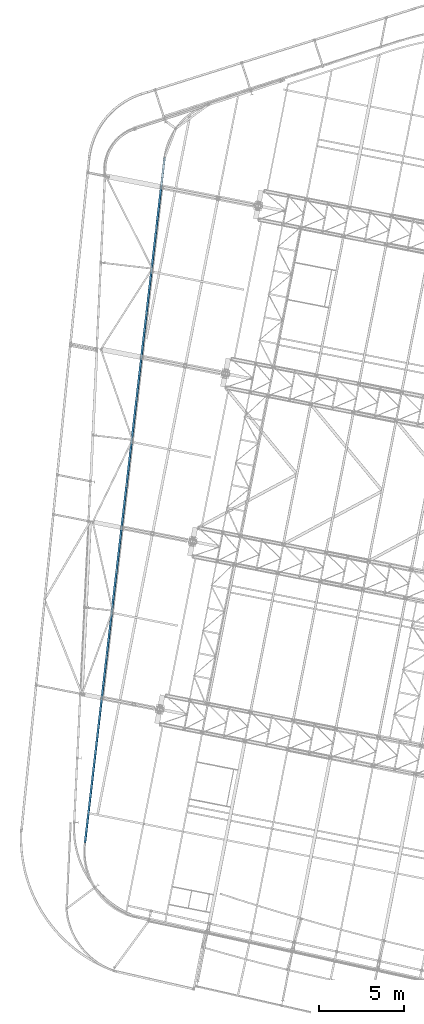
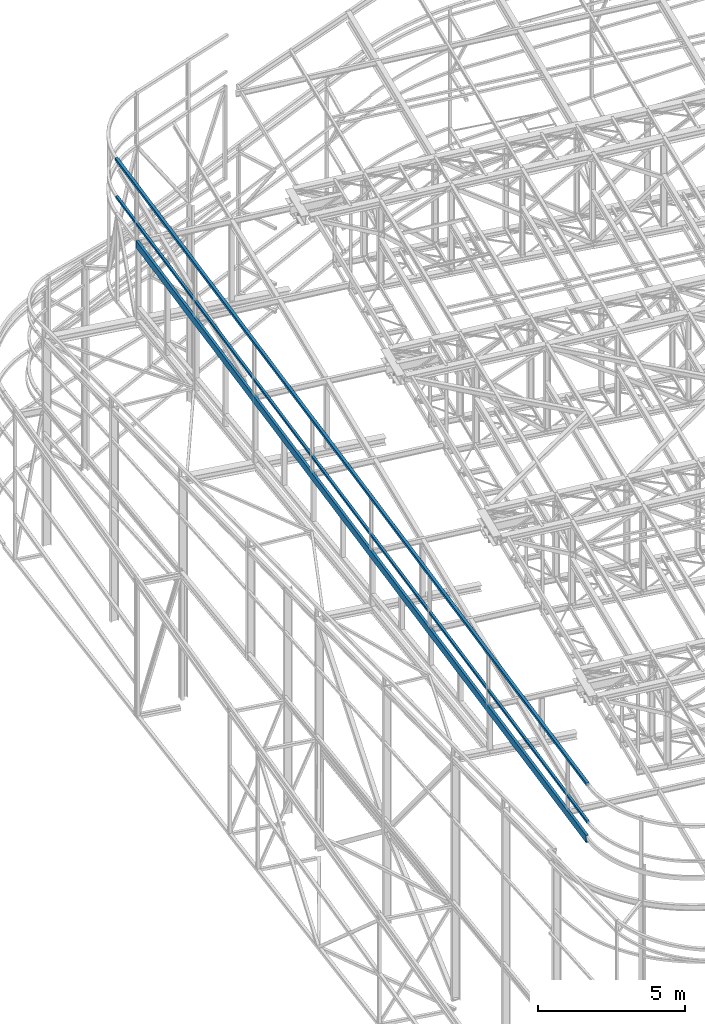
# One storey, part 66 of 215: 3 beams, 3 elements without a shape of their own.
"""IFC2X3 building model written with IfcOpenShell, lengths in millimetres."""

from ifc_helpers import new_model, si_unit, frame, origin_with_axes, origin_2d_with_axis, place, context, subcontext, project, spatial, hollow_rectangle, u_section, extrude, material, type_object, element, aggregate, save


model = new_model("IFC2X3")

# Units and contexts
model_context = context("Model", 3, precision=1e-05, world=origin_with_axes())
body_context = subcontext(model_context, "Body", "Model", "MODEL_VIEW")
ifc_project = project(units=[si_unit("LENGTHUNIT", "METRE", prefix="MILLI"), si_unit("AREAUNIT", "SQUARE_METRE"), si_unit("VOLUMEUNIT", "CUBIC_METRE"), si_unit("MASSUNIT", "GRAM", prefix="KILO"), si_unit("TIMEUNIT", "SECOND"), si_unit("PLANEANGLEUNIT", "RADIAN"), si_unit("SOLIDANGLEUNIT", "STERADIAN"), si_unit("THERMODYNAMICTEMPERATUREUNIT", "DEGREE_CELSIUS"), si_unit("LUMINOUSINTENSITYUNIT", "LUMEN")], contexts=[model_context])

# Site, building, storey
site_placement = place(None, origin_with_axes())
site = spatial("IfcSite", under=ifc_project, at=site_placement, CompositionType="ELEMENT")
building_placement = place(site_placement, origin_with_axes())
building = spatial("IfcBuilding", under=site, at=building_placement, Name="Undefined", CompositionType="ELEMENT")
storey_placement = place(building_placement, origin_with_axes())
storey = spatial("IfcBuildingStorey", under=building, at=storey_placement, Name="Undefined", CompositionType="ELEMENT", Elevation=0.0)

# Assembly, beam
assembly_1_placement = place(storey_placement, origin_with_axes())
assembly_1 = element("IfcElementAssembly", 1, at=assembly_1_placement, inside=storey, Name="Steel Assembly", AssemblyPlace="NOTDEFINED", PredefinedType="RIGID_FRAME")
ifc_material = material(Name="STEEL/S275JR")
beam_type_1 = type_object("IfcBeamType", PredefinedType="NOTDEFINED")
beam_1_placement = place(assembly_1_placement, frame((37888.564515659, 15374.6886279796, 12588.9969858313), z_axis=(0.0, 0.0, 1.0), x_axis=(0.11534938804668, 0.993324981401986, 0.0)))
beam_1 = element("IfcBeam", 2, at=beam_1_placement, type_object=beam_type_1, material=ifc_material, Name="LISSE", context=body_context, shape_type="SweptSolid", body=[
    extrude(hollow_rectangle(XDim=100.0, YDim=100.0, WallThickness=4.0, InnerFilletRadius=4.0, OuterFilletRadius=8.0, at=origin_2d_with_axis()), frame((40348.048621804, 0.0, -1.81898940354586e-12), z_axis=(-1.0, 0.0, 0.0), x_axis=(-6.93889390390723e-18, -1.0, -3.46944695195361e-18)), (0.0, 0.0, 1.0), 40348.0),
])
aggregate(assembly_1, [beam_1])

assembly_2_placement = place(storey_placement, origin_with_axes())
assembly_2 = element("IfcElementAssembly", 3, at=assembly_2_placement, inside=storey, Name="Steel Assembly", AssemblyPlace="NOTDEFINED", PredefinedType="RIGID_FRAME")
beam_type_2 = type_object("IfcBeamType", PredefinedType="NOTDEFINED")
beam_2_placement = place(assembly_2_placement, frame((37877.5922889289, 15385.4801741886, 14159.9969862569), z_axis=(0.0, 0.0, 1.0), x_axis=(0.11534938804668, 0.993324981401986, 0.0)))
beam_2 = element("IfcBeam", 4, at=beam_2_placement, type_object=beam_type_2, material=ifc_material, Name="LISSE", context=body_context, shape_type="SweptSolid", body=[
    extrude(hollow_rectangle(XDim=120.0, YDim=120.0, WallThickness=4.0, InnerFilletRadius=4.0, OuterFilletRadius=8.0, at=origin_2d_with_axis()), frame((40348.048621804, 0.0, -1.81898940354586e-12), z_axis=(-1.0, 0.0, 0.0), x_axis=(-6.93889390390723e-18, -1.0, -3.46944695195361e-18)), (0.0, 0.0, 1.0), 40348.0),
])
aggregate(assembly_2, [beam_2])

assembly_3_placement = place(storey_placement, origin_with_axes())
assembly_3 = element("IfcElementAssembly", 5, at=assembly_3_placement, inside=storey, Name="Steel Assembly", AssemblyPlace="NOTDEFINED", PredefinedType="RIGID_FRAME")
beam_type_3 = type_object("IfcBeamType", Name="UPE300", PredefinedType="NOTDEFINED")
beam_3_placement = place(assembly_3_placement, frame((37869.3595869536, 15399.0985244719, 11889.8724318932), z_axis=(0.000373211000041609, 0.00240841700028027, 0.999997030116141), x_axis=(0.115347334049362, 0.993322234425087, -0.00243539000104219)))
beam_3 = element("IfcBeam", 6, at=beam_3_placement, type_object=beam_type_3, material=ifc_material, ObjectType="UPE300", context=body_context, shape_type="SweptSolid", body=[
    extrude(u_section(Depth=300.0, FlangeWidth=100.0, WebThickness=9.5, FlangeThickness=15.0, FilletRadius=15.0, at=origin_2d_with_axis()), frame((38543.9666840257, -4.43397720976919e-13, -1.78555784161383e-12), z_axis=(-1.0, 0.0, 0.0), x_axis=(-6.93889390390723e-18, -1.0, -3.46944695195361e-18)), (0.0, 0.0, 1.0), 38544.0),
])
aggregate(assembly_3, [beam_3])

save(model, "model.ifc")
